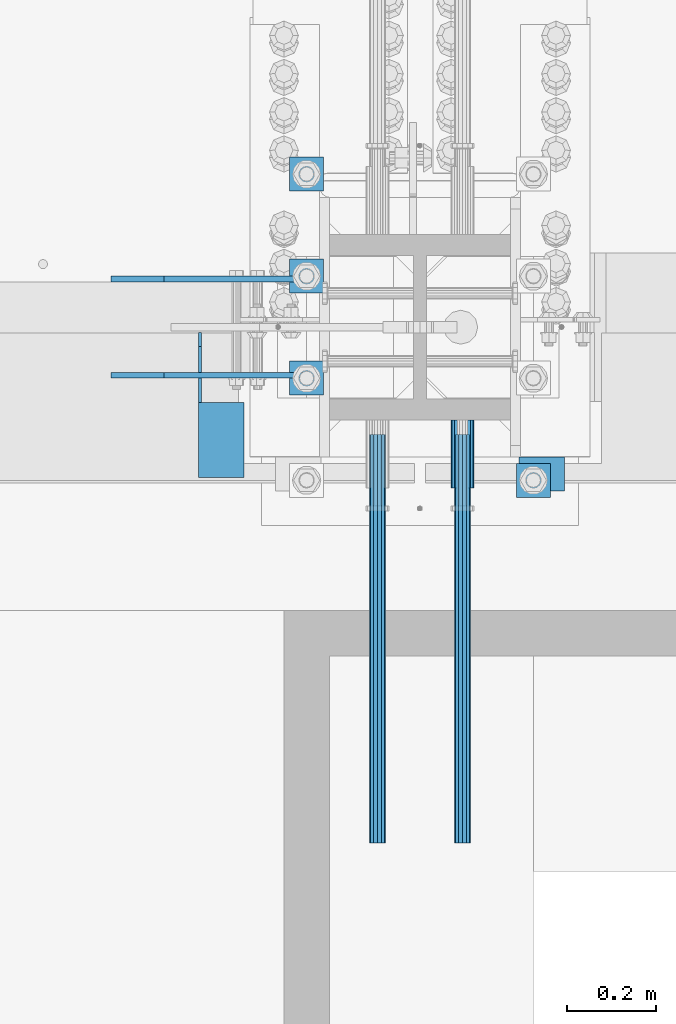
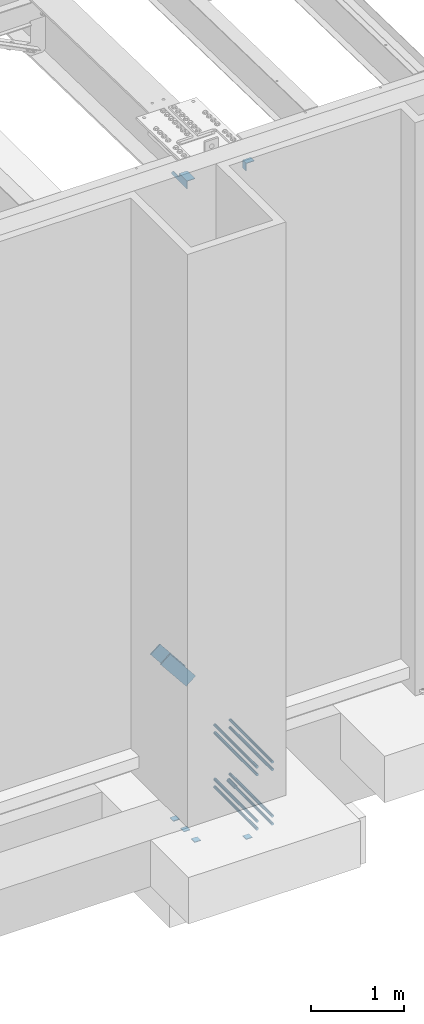
# One storey, part 1289 of 1763: 15 beams, 2 members, 13 elements without a shape of their own.
"""IFC2X3 building model written with IfcOpenShell, lengths in millimetres."""

from ifc_helpers import new_model, si_unit, frame, origin_with_axes, place, context, subcontext, project, spatial, faceted_brep, material, type_object, element, aggregate, save


model = new_model("IFC2X3")

# Units and contexts
model_context = context("Model", 3, precision=1e-05, world=origin_with_axes())
body_context = subcontext(model_context, "Body", "Model", "MODEL_VIEW")
ifc_project = project(units=[si_unit("LENGTHUNIT", "METRE", prefix="MILLI"), si_unit("AREAUNIT", "SQUARE_METRE"), si_unit("VOLUMEUNIT", "CUBIC_METRE"), si_unit("MASSUNIT", "GRAM", prefix="KILO"), si_unit("TIMEUNIT", "SECOND"), si_unit("PLANEANGLEUNIT", "RADIAN"), si_unit("SOLIDANGLEUNIT", "STERADIAN"), si_unit("THERMODYNAMICTEMPERATUREUNIT", "DEGREE_CELSIUS"), si_unit("LUMINOUSINTENSITYUNIT", "LUMEN")], contexts=[model_context])

# Site, building, storey
site_placement = place(None, origin_with_axes())
site = spatial("IfcSite", under=ifc_project, at=site_placement, CompositionType="ELEMENT")
building_placement = place(site_placement, origin_with_axes())
building = spatial("IfcBuilding", under=site, at=building_placement, Name="Undefined", CompositionType="ELEMENT")
storey_placement = place(building_placement, origin_with_axes())
storey = spatial("IfcBuildingStorey", under=building, at=storey_placement, Name="Undefined", CompositionType="ELEMENT", Elevation=0.0)

# Assembly, beam
assembly_1_placement = place(storey_placement, origin_with_axes())
assembly_1 = element("IfcElementAssembly", 1, at=assembly_1_placement, inside=storey, Name="COLUMN", AssemblyPlace="NOTDEFINED", PredefinedType="RIGID_FRAME")
ifc_material_1 = material(Name="STEEL/A36")
beam_type_1 = type_object("IfcBeamType", Name="L4X4X1/4", PredefinedType="NOTDEFINED")
beam_1_placement = place(assembly_1_placement, frame((-23754.7872728616, -14006.5123340175, 12153.9000001333), z_axis=(0.0, 0.0, -1.0), x_axis=(0.0, -1.0, 0.0)))
beam_1 = element("IfcBeam", 2, at=beam_1_placement, type_object=beam_type_1, material=ifc_material_1, Name="BRACE", ObjectType="L4X4X1/4", context=body_context, shape_type="Brep", body=[
    faceted_brep([(-3.63797880709171e-11, 50.8000000000011, -50.8000000000538), (-1.96450855582952e-10, 50.8000000000393, 50.7999999999374), (76.2000000000007, 50.7999999999993, 50.7999999999993), (76.2000000000007, 50.7999999999993, -50.7999999999993), (-1.81898940354586e-10, 44.4500000000371, 50.7999999999374), (76.2000000000007, 44.4500000000007, 50.7999999999993), (-2.18278728425503e-11, 44.4500000000007, -44.450000000048), (76.2000000000007, 44.4500000000007, -44.4500000000007), (1.96450855582952e-10, -50.8000000000338, -44.4499999999534), (76.2000000000007, -50.7999999999993, -44.4500000000007), (2.11002770811319e-10, -50.8000000000357, -50.799999999952), (76.2000000000007, -50.7999999999993, -50.7999999999993)], [[[0, 1, 2, 3]], [[1, 4, 5, 2]], [[4, 6, 7, 5]], [[6, 8, 9, 7]], [[8, 10, 11, 9]], [[10, 0, 3, 11]], [[5, 7, 9, 11, 3, 2]], [[10, 8, 6, 4, 1, 0]]]),
])
aggregate(assembly_1, [beam_1])

assembly_2_placement = place(storey_placement, origin_with_axes())
assembly_2 = element("IfcElementAssembly", 3, at=assembly_2_placement, inside=storey, Name="BEAM", AssemblyPlace="NOTDEFINED", PredefinedType="RIGID_FRAME")
beam_2_placement = place(assembly_2_placement, frame((-24473.2055562795, -13727.9060686172, 12153.8999999997), z_axis=(0.0, 0.0, -1.0), x_axis=(0.0, -1.0, 0.0)))
beam_2 = element("IfcBeam", 4, at=beam_2_placement, type_object=beam_type_1, material=ifc_material_1, Name="BRACE", ObjectType="L4X4X1/4", context=body_context, shape_type="Brep", body=[
    faceted_brep([(156.368567097667, 44.4500000000007, -6.34999980941575), (156.368567097667, 50.7999999999993, -6.34999980941575), (156.368568386746, 50.7999999999993, -50.7999999999993), (156.368568386746, -50.7999999999993, -50.7999999999993), (156.368568202592, -50.7999999999993, -44.4500000000007), (156.368568202592, 44.4500000000007, -44.4500000000007), (31.7499984742426, 44.4500000000007, -6.35000000027321), (31.7499984742426, 50.7999999999993, -6.35000038323415), (-1.81898940354586e-10, 44.4500000000371, 50.7999999999374), (-1.96450855582952e-10, 50.8000000000393, 50.7999999999374), (0.0, 50.7999999999993, 25.3999999997268), (0.0, 44.4500000000007, 25.3999999997268), (324.643737794, 44.4500000000007, 50.7999999999993), (324.643737794, 50.7999999999993, 50.7999999999993), (324.643737794, 44.4500000000007, -44.4500000000007), (324.643737794, -50.7999999999993, -44.4500000000007), (324.643737794, -50.7999999999993, -50.7999999999993), (324.643737794, 50.7999999999993, -50.7999999999993)], [[[0, 1, 2, 3, 4, 5]], [[1, 0, 6, 7]], [[8, 9, 10, 11]], [[9, 8, 12, 13]], [[12, 14, 15, 16, 17, 13]], [[15, 14, 5, 4]], [[16, 15, 4, 3]], [[17, 16, 3, 2]], [[9, 13, 17, 2, 1, 7, 10]], [[6, 11, 10, 7]], [[0, 5, 14, 12, 8, 11, 6]]]),
])
aggregate(assembly_2, [beam_2])

# Assembly, members
assembly_3_placement = place(storey_placement, origin_with_axes())
assembly_3 = element("IfcElementAssembly", 5, at=assembly_3_placement, inside=storey, Name="V. BRACE", AssemblyPlace="NOTDEFINED", PredefinedType="RIGID_FRAME")
member_type = type_object("IfcMemberType", PredefinedType="NOTDEFINED")
member_1_placement = place(assembly_3_placement, frame((-24661.1130788545, -13608.05, 5845.3684065153), z_axis=(0.780585099299328, 0.0, 0.625049520239683), x_axis=(0.625049520239684, 0.0, -0.780585099299327)))
member_1 = element("IfcMember", 6, at=member_1_placement, type_object=member_type, material=ifc_material_1, Name="PLATE", context=body_context, shape_type="Brep", body=[
    faceted_brep([(4.36557456851006e-11, 6.35000000000036, -76.2000000000044), (-4.72937244921923e-11, 6.35000000000036, 76.1999999999898), (507.999999999498, 6.35000000000036, 76.1999999995642), (507.999999999589, 6.35000000000036, -76.20000000043), (-4.72937244921923e-11, -6.35000000000036, 76.1999999999898), (507.999999999498, -6.35000000000036, 76.1999999995642), (4.36557456851006e-11, -6.35000000000036, -76.2000000000044), (507.999999999589, -6.35000000000036, -76.20000000043)], [[[0, 1, 2, 3]], [[1, 4, 5, 2]], [[4, 6, 7, 5]], [[6, 0, 3, 7]], [[5, 7, 3, 2]], [[6, 4, 1, 0]]]),
])
member_2_placement = place(assembly_3_placement, frame((-24661.1130788545, -13823.95, 5845.3684065153), z_axis=(0.780585099299328, 0.0, 0.625049520239683), x_axis=(0.625049520239684, 0.0, -0.780585099299327)))
member_2 = element("IfcMember", 7, at=member_2_placement, type_object=member_type, material=ifc_material_1, Name="PLATE", context=body_context, shape_type="Brep", body=[
    faceted_brep([(4.36557456851006e-11, 6.35000000000036, -76.2000000000044), (-4.72937244921923e-11, 6.35000000000036, 76.1999999999898), (507.999999999498, 6.35000000000036, 76.1999999995642), (507.999999999589, 6.35000000000036, -76.20000000043), (-4.72937244921923e-11, -6.35000000000036, 76.1999999999898), (507.999999999498, -6.35000000000036, 76.1999999995642), (4.36557456851006e-11, -6.35000000000036, -76.2000000000044), (507.999999999589, -6.35000000000036, -76.20000000043)], [[[0, 1, 2, 3]], [[1, 4, 5, 2]], [[4, 6, 7, 5]], [[6, 0, 3, 7]], [[5, 7, 3, 2]], [[6, 4, 1, 0]]]),
])
aggregate(assembly_3, [member_1, member_2])

# Assembly, beams
assembly_4_placement = place(storey_placement, origin_with_axes())
assembly_4 = element("IfcElementAssembly", 8, at=assembly_4_placement, inside=storey, Name="TEMPLATE", AssemblyPlace="NOTDEFINED", PredefinedType="RIGID_FRAME")
beam_type_2 = type_object("IfcBeamType", PredefinedType="NOTDEFINED")
beam_3_placement = place(assembly_4_placement, frame((-23773.8372736984, -14097.0000000001, 3348.0375), z_axis=(1.0, 0.0, 0.0), x_axis=(0.0, 1.0, 0.0)))
beam_3 = element("IfcBeam", 9, at=beam_3_placement, type_object=beam_type_2, material=ifc_material_1, Name="WASHER PLATE", context=body_context, shape_type="Brep", body=[
    faceted_brep([(0.0, 4.76249999999709, -38.1000000000004), (0.0, 4.76249999999709, 38.1000000000004), (76.2000000000007, 4.76249999999982, 38.0999999999985), (76.2000000000007, 4.76249999999982, -38.0999999999985), (0.0, -4.76249999999709, 38.1000000000004), (76.2000000000007, -4.76249999999982, 38.0999999999985), (0.0, -4.76249999999709, -38.1000000000004), (76.2000000000007, -4.76249999999982, -38.0999999999985)], [[[0, 1, 2, 3]], [[1, 4, 5, 2]], [[4, 6, 7, 5]], [[6, 0, 3, 7]], [[5, 7, 3, 2]], [[6, 4, 1, 0]]]),
])
beam_4_placement = place(assembly_4_placement, frame((-24281.8372736984, -13868.4000000001, 3348.0375), z_axis=(1.0, 0.0, 0.0), x_axis=(0.0, 1.0, 0.0)))
beam_4 = element("IfcBeam", 10, at=beam_4_placement, type_object=beam_type_2, material=ifc_material_1, Name="WASHER PLATE", context=body_context, shape_type="Brep", body=[
    faceted_brep([(0.0, 4.76249999999709, -38.1000000000004), (0.0, 4.76249999999709, 38.1000000000004), (76.2000000000007, 4.76249999999982, 38.0999999999985), (76.2000000000007, 4.76249999999982, -38.0999999999985), (0.0, -4.76249999999709, 38.1000000000004), (76.2000000000007, -4.76249999999982, 38.0999999999985), (0.0, -4.76249999999709, -38.1000000000004), (76.2000000000007, -4.76249999999982, -38.0999999999985)], [[[0, 1, 2, 3]], [[1, 4, 5, 2]], [[4, 6, 7, 5]], [[6, 0, 3, 7]], [[5, 7, 3, 2]], [[6, 4, 1, 0]]]),
])
beam_5_placement = place(assembly_4_placement, frame((-24281.8372736984, -13639.8000000001, 3348.0375), z_axis=(1.0, 0.0, 0.0), x_axis=(0.0, 1.0, 0.0)))
beam_5 = element("IfcBeam", 11, at=beam_5_placement, type_object=beam_type_2, material=ifc_material_1, Name="WASHER PLATE", context=body_context, shape_type="Brep", body=[
    faceted_brep([(0.0, 4.76249999999709, -38.1000000000004), (0.0, 4.76249999999709, 38.1000000000004), (76.2000000000007, 4.76249999999982, 38.0999999999985), (76.2000000000007, 4.76249999999982, -38.0999999999985), (0.0, -4.76249999999709, 38.1000000000004), (76.2000000000007, -4.76249999999982, 38.0999999999985), (0.0, -4.76249999999709, -38.1000000000004), (76.2000000000007, -4.76249999999982, -38.0999999999985)], [[[0, 1, 2, 3]], [[1, 4, 5, 2]], [[4, 6, 7, 5]], [[6, 0, 3, 7]], [[5, 7, 3, 2]], [[6, 4, 1, 0]]]),
])
beam_6_placement = place(assembly_4_placement, frame((-24281.8372736984, -13411.2000000001, 3348.0375), z_axis=(1.0, 0.0, 0.0), x_axis=(0.0, 1.0, 0.0)))
beam_6 = element("IfcBeam", 12, at=beam_6_placement, type_object=beam_type_2, material=ifc_material_1, Name="WASHER PLATE", context=body_context, shape_type="Brep", body=[
    faceted_brep([(0.0, 4.76249999999709, -38.1000000000004), (0.0, 4.76249999999709, 38.1000000000004), (76.2000000000007, 4.76249999999982, 38.0999999999985), (76.2000000000007, 4.76249999999982, -38.0999999999985), (0.0, -4.76249999999709, 38.1000000000004), (76.2000000000007, -4.76249999999982, 38.0999999999985), (0.0, -4.76249999999709, -38.1000000000004), (76.2000000000007, -4.76249999999982, -38.0999999999985)], [[[0, 1, 2, 3]], [[1, 4, 5, 2]], [[4, 6, 7, 5]], [[6, 0, 3, 7]], [[5, 7, 3, 2]], [[6, 4, 1, 0]]]),
])
aggregate(assembly_4, [beam_3, beam_4, beam_5, beam_6])

# Assembly, beam
assembly_5_placement = place(storey_placement, origin_with_axes())
assembly_5 = element("IfcElementAssembly", 13, at=assembly_5_placement, inside=storey, Name="HALF COUPLER", AssemblyPlace="NOTDEFINED", PredefinedType="RIGID_FRAME")
ifc_material_2 = material(Name="STEEL/A706-GR.80")
beam_type_3 = type_object("IfcBeamType", PredefinedType="NOTDEFINED")
beam_7_placement = place(assembly_5_placement, frame((-23932.5872736985, -13923.9622483743, 4064.0), z_axis=(0.0, 0.0, 1.0), x_axis=(0.0, -1.0, 0.0)))
beam_7 = element("IfcBeam", 14, at=beam_7_placement, type_object=beam_type_3, material=ifc_material_2, Name="HALF COUPLER", context=body_context, shape_type="Brep", body=[
    faceted_brep([(32.7659999999996, -8.95349999999962, -15.507916905568), (32.7659999999996, 0.0, -17.9070000000002), (32.7659999999996, 8.95349999999962, -15.507916905568), (32.7659999999996, 15.507916905568, -8.95350000000008), (32.7659999999996, 17.9069999999992, 0.0), (32.7659999999996, 15.507916905568, 8.95350000000008), (32.7659999999996, 8.95349999999962, 15.507916905568), (32.7659999999996, 0.0, 17.9070000000002), (32.7659999999996, -8.95349999999962, 15.507916905568), (32.7659999999996, -15.507916905568, 8.95350000000008), (32.7659999999996, -17.9069999999992, 0.0), (32.7659999999996, -15.507916905568, -8.95350000000008), (152.400103102711, -15.507916905568, 8.95350000000008), (152.400103102711, -8.95349999999962, 15.507916905568), (152.400103102711, -17.9069999999992, 0.0), (152.400103102711, -15.507916905568, -8.95350000000008), (152.400103102711, -8.95349999999962, -15.507916905568), (152.400103102711, 0.0, -17.9070000000002), (152.400103102711, 8.95349999999962, -15.507916905568), (152.400103102711, 15.507916905568, -8.95350000000008), (152.400103102711, 17.9069999999992, 0.0), (152.400103102711, 15.507916905568, 8.95350000000008), (152.400103102711, 8.95349999999962, 15.507916905568), (152.400103102711, 0.0, 17.9070000000002), (0.0, -23.466540125788, 9.72015918207308), (0.0, -17.9605122421381, 17.9605122421385), (0.0, -9.72015918207398, 23.4665401257867), (0.0, 0.0, 25.4000000000001), (0.0, 9.72015918207398, 23.4665401257867), (0.0, 17.9605122421381, 17.9605122421385), (0.0, 23.466540125788, 9.72015918207308), (0.0, 25.4000000000015, 0.0), (0.0, 23.466540125788, -9.72015918207308), (0.0, 17.9605122421381, -17.9605122421385), (0.0, 9.72015918207398, -23.4665401257867), (0.0, 0.0, -25.4000000000001), (0.0, -9.72015918207398, -23.4665401257867), (0.0, -17.9605122421381, -17.9605122421385), (0.0, -23.466540125788, -9.72015918207308), (0.0, -25.4000000000015, 0.0), (152.400103102711, -25.4000000000015, 0.0), (152.400103102711, -23.466540125788, 9.72015918207308), (152.400103102711, -17.9605122421381, 17.9605122421385), (152.400103102711, -9.72015918207398, 23.4665401257867), (152.400103102711, 0.0, 25.4000000000001), (152.400103102711, 9.72015918207398, 23.4665401257867), (152.400103102711, 17.9605122421381, 17.9605122421385), (152.400103102711, 23.466540125788, 9.72015918207308), (152.400103102711, 25.4000000000015, 0.0), (152.400103102711, 23.466540125788, -9.72015918207308), (152.400103102711, 17.9605122421381, -17.9605122421385), (152.400103102711, 9.72015918207398, -23.4665401257867), (152.400103102711, 0.0, -25.4000000000001), (152.400103102711, -9.72015918207398, -23.4665401257867), (152.400103102711, -17.9605122421381, -17.9605122421385), (152.400103102711, -23.466540125788, -9.72015918207308)], [[[0, 1, 2, 3, 4, 5, 6, 7, 8, 9, 10, 11]], [[12, 9, 8, 13]], [[14, 10, 9, 12]], [[15, 11, 10, 14]], [[16, 0, 11, 15]], [[17, 1, 0, 16]], [[18, 2, 1, 17]], [[19, 3, 2, 18]], [[20, 4, 3, 19]], [[21, 5, 4, 20]], [[22, 6, 5, 21]], [[23, 7, 6, 22]], [[13, 8, 7, 23]], [[24, 25, 26, 27, 28, 29, 30, 31, 32, 33, 34, 35, 36, 37, 38, 39]], [[24, 39, 40, 41]], [[25, 24, 41, 42]], [[26, 25, 42, 43]], [[27, 26, 43, 44]], [[28, 27, 44, 45]], [[29, 28, 45, 46]], [[30, 29, 46, 47]], [[31, 30, 47, 48]], [[32, 31, 48, 49]], [[33, 32, 49, 50]], [[34, 33, 50, 51]], [[35, 34, 51, 52]], [[36, 35, 52, 53]], [[37, 36, 53, 54]], [[38, 37, 54, 55]], [[39, 38, 55, 40]], [[54, 53, 52, 51, 50, 49, 48, 47, 46, 45, 44, 43, 42, 41, 40, 55], [21, 20, 19, 18, 17, 16, 15, 14, 12, 13, 23, 22]]]),
])
aggregate(assembly_5, [beam_7])

assembly_6_placement = place(storey_placement, origin_with_axes())
assembly_6 = element("IfcElementAssembly", 15, at=assembly_6_placement, inside=storey, Name="REBAR", AssemblyPlace="NOTDEFINED", PredefinedType="RIGID_FRAME")
beam_type_4 = type_object("IfcBeamType", Name="#11 REBAR", PredefinedType="NOTDEFINED")
beam_8_placement = place(assembly_6_placement, frame((-23932.5872736985, -13956.7282483743, 4165.60000000009), z_axis=(0.0, 0.0, 1.0), x_axis=(0.0, -1.0, 0.0)))
beam_8 = element("IfcBeam", 16, at=beam_8_placement, type_object=beam_type_4, material=ifc_material_2, Name="REBAR", ObjectType="#11 REBAR", context=body_context, shape_type="Brep", body=[
    faceted_brep([(0.0, -17.9069999999992, 0.0), (0.0, -15.507916905568, -8.95349999999962), (914.400000001086, -15.507916905568, -8.95349999999962), (914.400000001086, -17.9069999999992, 0.0), (0.0, -8.95349999999962, -15.507916905568), (914.400000001086, -8.95349999999962, -15.507916905568), (0.0, 0.0, -17.9070000000002), (914.400000001086, 0.0, -17.9070000000002), (0.0, 8.95349999999962, -15.507916905568), (914.400000001086, 8.95349999999962, -15.507916905568), (0.0, 15.507916905568, -8.95349999999962), (914.400000001086, 15.507916905568, -8.95349999999962), (0.0, 17.9069999999992, 0.0), (914.400000001086, 17.9069999999992, 0.0), (0.0, 15.507916905568, 8.95349999999962), (914.400000001086, 15.507916905568, 8.95349999999962), (0.0, 8.95349999999962, 15.507916905568), (914.400000001086, 8.95349999999962, 15.507916905568), (0.0, 0.0, 17.9070000000002), (914.400000001086, 0.0, 17.9070000000002), (0.0, -8.95349999999962, 15.507916905568), (914.400000001086, -8.95349999999962, 15.507916905568), (0.0, -15.507916905568, 8.95349999999962), (914.400000001086, -15.507916905568, 8.95349999999962)], [[[0, 1, 2, 3]], [[1, 4, 5, 2]], [[4, 6, 7, 5]], [[6, 8, 9, 7]], [[8, 10, 11, 9]], [[10, 12, 13, 11]], [[12, 14, 15, 13]], [[14, 16, 17, 15]], [[16, 18, 19, 17]], [[18, 20, 21, 19]], [[20, 22, 23, 21]], [[22, 0, 3, 23]], [[5, 7, 9, 11, 13, 15, 17, 19, 21, 23, 3, 2]], [[22, 20, 18, 16, 14, 12, 10, 8, 6, 4, 1, 0]]]),
])
aggregate(assembly_6, [beam_8])

assembly_7_placement = place(storey_placement, origin_with_axes())
assembly_7 = element("IfcElementAssembly", 17, at=assembly_7_placement, inside=storey, Name="REBAR", AssemblyPlace="NOTDEFINED", PredefinedType="RIGID_FRAME")
beam_9_placement = place(assembly_7_placement, frame((-24123.0872736984, -13956.7283171098, 4165.60000000009), z_axis=(0.0, 0.0, 1.0), x_axis=(0.0, -1.0, 0.0)))
beam_9 = element("IfcBeam", 18, at=beam_9_placement, type_object=beam_type_4, material=ifc_material_2, Name="REBAR", ObjectType="#11 REBAR", context=body_context, shape_type="Brep", body=[
    faceted_brep([(0.0, -17.9069999999992, 0.0), (0.0, -15.507916905568, -8.95349999999962), (914.400000001086, -15.507916905568, -8.95349999999962), (914.400000001086, -17.9069999999992, 0.0), (0.0, -8.95349999999962, -15.507916905568), (914.400000001086, -8.95349999999962, -15.507916905568), (0.0, 0.0, -17.9070000000002), (914.400000001086, 0.0, -17.9070000000002), (0.0, 8.95349999999962, -15.507916905568), (914.400000001086, 8.95349999999962, -15.507916905568), (0.0, 15.507916905568, -8.95349999999962), (914.400000001086, 15.507916905568, -8.95349999999962), (0.0, 17.9069999999992, 0.0), (914.400000001086, 17.9069999999992, 0.0), (0.0, 15.507916905568, 8.95349999999962), (914.400000001086, 15.507916905568, 8.95349999999962), (0.0, 8.95349999999962, 15.507916905568), (914.400000001086, 8.95349999999962, 15.507916905568), (0.0, 0.0, 17.9070000000002), (914.400000001086, 0.0, 17.9070000000002), (0.0, -8.95349999999962, 15.507916905568), (914.400000001086, -8.95349999999962, 15.507916905568), (0.0, -15.507916905568, 8.95349999999962), (914.400000001086, -15.507916905568, 8.95349999999962)], [[[0, 1, 2, 3]], [[1, 4, 5, 2]], [[4, 6, 7, 5]], [[6, 8, 9, 7]], [[8, 10, 11, 9]], [[10, 12, 13, 11]], [[12, 14, 15, 13]], [[14, 16, 17, 15]], [[16, 18, 19, 17]], [[18, 20, 21, 19]], [[20, 22, 23, 21]], [[22, 0, 3, 23]], [[5, 7, 9, 11, 13, 15, 17, 19, 21, 23, 3, 2]], [[22, 20, 18, 16, 14, 12, 10, 8, 6, 4, 1, 0]]]),
])
aggregate(assembly_7, [beam_9])

assembly_8_placement = place(storey_placement, origin_with_axes())
assembly_8 = element("IfcElementAssembly", 19, at=assembly_8_placement, inside=storey, Name="REBAR", AssemblyPlace="NOTDEFINED", PredefinedType="RIGID_FRAME")
beam_10_placement = place(assembly_8_placement, frame((-23932.5872736985, -13956.7282483743, 4064.00000000009), z_axis=(0.0, 0.0, 1.0), x_axis=(0.0, -1.0, 0.0)))
beam_10 = element("IfcBeam", 20, at=beam_10_placement, type_object=beam_type_4, material=ifc_material_2, Name="REBAR", ObjectType="#11 REBAR", context=body_context, shape_type="Brep", body=[
    faceted_brep([(0.0, -17.9069999999992, 0.0), (0.0, -15.507916905568, -8.95349999999962), (914.400000001086, -15.507916905568, -8.95349999999962), (914.400000001086, -17.9069999999992, 0.0), (0.0, -8.95349999999962, -15.507916905568), (914.400000001086, -8.95349999999962, -15.507916905568), (0.0, 0.0, -17.9070000000002), (914.400000001086, 0.0, -17.9070000000002), (0.0, 8.95349999999962, -15.507916905568), (914.400000001086, 8.95349999999962, -15.507916905568), (0.0, 15.507916905568, -8.95349999999962), (914.400000001086, 15.507916905568, -8.95349999999962), (0.0, 17.9069999999992, 0.0), (914.400000001086, 17.9069999999992, 0.0), (0.0, 15.507916905568, 8.95349999999962), (914.400000001086, 15.507916905568, 8.95349999999962), (0.0, 8.95349999999962, 15.507916905568), (914.400000001086, 8.95349999999962, 15.507916905568), (0.0, 0.0, 17.9070000000002), (914.400000001086, 0.0, 17.9070000000002), (0.0, -8.95349999999962, 15.507916905568), (914.400000001086, -8.95349999999962, 15.507916905568), (0.0, -15.507916905568, 8.95349999999962), (914.400000001086, -15.507916905568, 8.95349999999962)], [[[0, 1, 2, 3]], [[1, 4, 5, 2]], [[4, 6, 7, 5]], [[6, 8, 9, 7]], [[8, 10, 11, 9]], [[10, 12, 13, 11]], [[12, 14, 15, 13]], [[14, 16, 17, 15]], [[16, 18, 19, 17]], [[18, 20, 21, 19]], [[20, 22, 23, 21]], [[22, 0, 3, 23]], [[5, 7, 9, 11, 13, 15, 17, 19, 21, 23, 3, 2]], [[22, 20, 18, 16, 14, 12, 10, 8, 6, 4, 1, 0]]]),
])
aggregate(assembly_8, [beam_10])

assembly_9_placement = place(storey_placement, origin_with_axes())
assembly_9 = element("IfcElementAssembly", 21, at=assembly_9_placement, inside=storey, Name="REBAR", AssemblyPlace="NOTDEFINED", PredefinedType="RIGID_FRAME")
beam_11_placement = place(assembly_9_placement, frame((-24123.0872736984, -13956.7283171098, 4064.00000000009), z_axis=(0.0, 0.0, 1.0), x_axis=(0.0, -1.0, 0.0)))
beam_11 = element("IfcBeam", 22, at=beam_11_placement, type_object=beam_type_4, material=ifc_material_2, Name="REBAR", ObjectType="#11 REBAR", context=body_context, shape_type="Brep", body=[
    faceted_brep([(0.0, -17.9069999999992, 0.0), (0.0, -15.507916905568, -8.95349999999962), (914.400000001086, -15.507916905568, -8.95349999999962), (914.400000001086, -17.9069999999992, 0.0), (0.0, -8.95349999999962, -15.507916905568), (914.400000001086, -8.95349999999962, -15.507916905568), (0.0, 0.0, -17.9070000000002), (914.400000001086, 0.0, -17.9070000000002), (0.0, 8.95349999999962, -15.507916905568), (914.400000001086, 8.95349999999962, -15.507916905568), (0.0, 15.507916905568, -8.95349999999962), (914.400000001086, 15.507916905568, -8.95349999999962), (0.0, 17.9069999999992, 0.0), (914.400000001086, 17.9069999999992, 0.0), (0.0, 15.507916905568, 8.95349999999962), (914.400000001086, 15.507916905568, 8.95349999999962), (0.0, 8.95349999999962, 15.507916905568), (914.400000001086, 8.95349999999962, 15.507916905568), (0.0, 0.0, 17.9070000000002), (914.400000001086, 0.0, 17.9070000000002), (0.0, -8.95349999999962, 15.507916905568), (914.400000001086, -8.95349999999962, 15.507916905568), (0.0, -15.507916905568, 8.95349999999962), (914.400000001086, -15.507916905568, 8.95349999999962)], [[[0, 1, 2, 3]], [[1, 4, 5, 2]], [[4, 6, 7, 5]], [[6, 8, 9, 7]], [[8, 10, 11, 9]], [[10, 12, 13, 11]], [[12, 14, 15, 13]], [[14, 16, 17, 15]], [[16, 18, 19, 17]], [[18, 20, 21, 19]], [[20, 22, 23, 21]], [[22, 0, 3, 23]], [[5, 7, 9, 11, 13, 15, 17, 19, 21, 23, 3, 2]], [[22, 20, 18, 16, 14, 12, 10, 8, 6, 4, 1, 0]]]),
])
aggregate(assembly_9, [beam_11])

assembly_10_placement = place(storey_placement, origin_with_axes())
assembly_10 = element("IfcElementAssembly", 23, at=assembly_10_placement, inside=storey, Name="REBAR", AssemblyPlace="NOTDEFINED", PredefinedType="RIGID_FRAME")
beam_12_placement = place(assembly_10_placement, frame((-23932.5872736985, -13956.7285233158, 4876.80000000009), z_axis=(0.0, 0.0, 1.0), x_axis=(0.0, -1.0, 0.0)))
beam_12 = element("IfcBeam", 24, at=beam_12_placement, type_object=beam_type_4, material=ifc_material_2, Name="REBAR", ObjectType="#11 REBAR", context=body_context, shape_type="Brep", body=[
    faceted_brep([(0.0, -17.9069999999992, 0.0), (0.0, -15.507916905568, -8.95349999999962), (914.400000001086, -15.507916905568, -8.95349999999962), (914.400000001086, -17.9069999999992, 0.0), (0.0, -8.95349999999962, -15.507916905568), (914.400000001086, -8.95349999999962, -15.507916905568), (0.0, 0.0, -17.9070000000002), (914.400000001086, 0.0, -17.9070000000002), (0.0, 8.95349999999962, -15.507916905568), (914.400000001086, 8.95349999999962, -15.507916905568), (0.0, 15.507916905568, -8.95349999999962), (914.400000001086, 15.507916905568, -8.95349999999962), (0.0, 17.9069999999992, 0.0), (914.400000001086, 17.9069999999992, 0.0), (0.0, 15.507916905568, 8.95349999999962), (914.400000001086, 15.507916905568, 8.95349999999962), (0.0, 8.95349999999962, 15.507916905568), (914.400000001086, 8.95349999999962, 15.507916905568), (0.0, 0.0, 17.9070000000002), (914.400000001086, 0.0, 17.9070000000002), (0.0, -8.95349999999962, 15.507916905568), (914.400000001086, -8.95349999999962, 15.507916905568), (0.0, -15.507916905568, 8.95349999999962), (914.400000001086, -15.507916905568, 8.95349999999962)], [[[0, 1, 2, 3]], [[1, 4, 5, 2]], [[4, 6, 7, 5]], [[6, 8, 9, 7]], [[8, 10, 11, 9]], [[10, 12, 13, 11]], [[12, 14, 15, 13]], [[14, 16, 17, 15]], [[16, 18, 19, 17]], [[18, 20, 21, 19]], [[20, 22, 23, 21]], [[22, 0, 3, 23]], [[5, 7, 9, 11, 13, 15, 17, 19, 21, 23, 3, 2]], [[22, 20, 18, 16, 14, 12, 10, 8, 6, 4, 1, 0]]]),
])
aggregate(assembly_10, [beam_12])

assembly_11_placement = place(storey_placement, origin_with_axes())
assembly_11 = element("IfcElementAssembly", 25, at=assembly_11_placement, inside=storey, Name="REBAR", AssemblyPlace="NOTDEFINED", PredefinedType="RIGID_FRAME")
beam_13_placement = place(assembly_11_placement, frame((-24123.0872736984, -13956.7285920513, 4876.80000000009), z_axis=(0.0, 0.0, 1.0), x_axis=(0.0, -1.0, 0.0)))
beam_13 = element("IfcBeam", 26, at=beam_13_placement, type_object=beam_type_4, material=ifc_material_2, Name="REBAR", ObjectType="#11 REBAR", context=body_context, shape_type="Brep", body=[
    faceted_brep([(0.0, -17.9069999999992, 0.0), (0.0, -15.507916905568, -8.95349999999962), (914.400000001086, -15.507916905568, -8.95349999999962), (914.400000001086, -17.9069999999992, 0.0), (0.0, -8.95349999999962, -15.507916905568), (914.400000001086, -8.95349999999962, -15.507916905568), (0.0, 0.0, -17.9070000000002), (914.400000001086, 0.0, -17.9070000000002), (0.0, 8.95349999999962, -15.507916905568), (914.400000001086, 8.95349999999962, -15.507916905568), (0.0, 15.507916905568, -8.95349999999962), (914.400000001086, 15.507916905568, -8.95349999999962), (0.0, 17.9069999999992, 0.0), (914.400000001086, 17.9069999999992, 0.0), (0.0, 15.507916905568, 8.95349999999962), (914.400000001086, 15.507916905568, 8.95349999999962), (0.0, 8.95349999999962, 15.507916905568), (914.400000001086, 8.95349999999962, 15.507916905568), (0.0, 0.0, 17.9070000000002), (914.400000001086, 0.0, 17.9070000000002), (0.0, -8.95349999999962, 15.507916905568), (914.400000001086, -8.95349999999962, 15.507916905568), (0.0, -15.507916905568, 8.95349999999962), (914.400000001086, -15.507916905568, 8.95349999999962)], [[[0, 1, 2, 3]], [[1, 4, 5, 2]], [[4, 6, 7, 5]], [[6, 8, 9, 7]], [[8, 10, 11, 9]], [[10, 12, 13, 11]], [[12, 14, 15, 13]], [[14, 16, 17, 15]], [[16, 18, 19, 17]], [[18, 20, 21, 19]], [[20, 22, 23, 21]], [[22, 0, 3, 23]], [[5, 7, 9, 11, 13, 15, 17, 19, 21, 23, 3, 2]], [[22, 20, 18, 16, 14, 12, 10, 8, 6, 4, 1, 0]]]),
])
aggregate(assembly_11, [beam_13])

assembly_12_placement = place(storey_placement, origin_with_axes())
assembly_12 = element("IfcElementAssembly", 27, at=assembly_12_placement, inside=storey, Name="REBAR", AssemblyPlace="NOTDEFINED", PredefinedType="RIGID_FRAME")
beam_14_placement = place(assembly_12_placement, frame((-23932.5872736985, -13956.7285233158, 4775.20000000009), z_axis=(0.0, 0.0, 1.0), x_axis=(0.0, -1.0, 0.0)))
beam_14 = element("IfcBeam", 28, at=beam_14_placement, type_object=beam_type_4, material=ifc_material_2, Name="REBAR", ObjectType="#11 REBAR", context=body_context, shape_type="Brep", body=[
    faceted_brep([(0.0, -17.9069999999992, 0.0), (0.0, -15.507916905568, -8.95349999999962), (914.400000001086, -15.507916905568, -8.95349999999962), (914.400000001086, -17.9069999999992, 0.0), (0.0, -8.95349999999962, -15.507916905568), (914.400000001086, -8.95349999999962, -15.507916905568), (0.0, 0.0, -17.9070000000002), (914.400000001086, 0.0, -17.9070000000002), (0.0, 8.95349999999962, -15.507916905568), (914.400000001086, 8.95349999999962, -15.507916905568), (0.0, 15.507916905568, -8.95349999999962), (914.400000001086, 15.507916905568, -8.95349999999962), (0.0, 17.9069999999992, 0.0), (914.400000001086, 17.9069999999992, 0.0), (0.0, 15.507916905568, 8.95349999999962), (914.400000001086, 15.507916905568, 8.95349999999962), (0.0, 8.95349999999962, 15.507916905568), (914.400000001086, 8.95349999999962, 15.507916905568), (0.0, 0.0, 17.9070000000002), (914.400000001086, 0.0, 17.9070000000002), (0.0, -8.95349999999962, 15.507916905568), (914.400000001086, -8.95349999999962, 15.507916905568), (0.0, -15.507916905568, 8.95349999999962), (914.400000001086, -15.507916905568, 8.95349999999962)], [[[0, 1, 2, 3]], [[1, 4, 5, 2]], [[4, 6, 7, 5]], [[6, 8, 9, 7]], [[8, 10, 11, 9]], [[10, 12, 13, 11]], [[12, 14, 15, 13]], [[14, 16, 17, 15]], [[16, 18, 19, 17]], [[18, 20, 21, 19]], [[20, 22, 23, 21]], [[22, 0, 3, 23]], [[5, 7, 9, 11, 13, 15, 17, 19, 21, 23, 3, 2]], [[22, 20, 18, 16, 14, 12, 10, 8, 6, 4, 1, 0]]]),
])
aggregate(assembly_12, [beam_14])

assembly_13_placement = place(storey_placement, origin_with_axes())
assembly_13 = element("IfcElementAssembly", 29, at=assembly_13_placement, inside=storey, Name="REBAR", AssemblyPlace="NOTDEFINED", PredefinedType="RIGID_FRAME")
beam_15_placement = place(assembly_13_placement, frame((-24123.0872736984, -13956.7285920513, 4775.20000000009), z_axis=(0.0, 0.0, 1.0), x_axis=(0.0, -1.0, 0.0)))
beam_15 = element("IfcBeam", 30, at=beam_15_placement, type_object=beam_type_4, material=ifc_material_2, Name="REBAR", ObjectType="#11 REBAR", context=body_context, shape_type="Brep", body=[
    faceted_brep([(0.0, -17.9069999999992, 0.0), (0.0, -15.507916905568, -8.95349999999962), (914.400000001086, -15.507916905568, -8.95349999999962), (914.400000001086, -17.9069999999992, 0.0), (0.0, -8.95349999999962, -15.507916905568), (914.400000001086, -8.95349999999962, -15.507916905568), (0.0, 0.0, -17.9070000000002), (914.400000001086, 0.0, -17.9070000000002), (0.0, 8.95349999999962, -15.507916905568), (914.400000001086, 8.95349999999962, -15.507916905568), (0.0, 15.507916905568, -8.95349999999962), (914.400000001086, 15.507916905568, -8.95349999999962), (0.0, 17.9069999999992, 0.0), (914.400000001086, 17.9069999999992, 0.0), (0.0, 15.507916905568, 8.95349999999962), (914.400000001086, 15.507916905568, 8.95349999999962), (0.0, 8.95349999999962, 15.507916905568), (914.400000001086, 8.95349999999962, 15.507916905568), (0.0, 0.0, 17.9070000000002), (914.400000001086, 0.0, 17.9070000000002), (0.0, -8.95349999999962, 15.507916905568), (914.400000001086, -8.95349999999962, 15.507916905568), (0.0, -15.507916905568, 8.95349999999962), (914.400000001086, -15.507916905568, 8.95349999999962)], [[[0, 1, 2, 3]], [[1, 4, 5, 2]], [[4, 6, 7, 5]], [[6, 8, 9, 7]], [[8, 10, 11, 9]], [[10, 12, 13, 11]], [[12, 14, 15, 13]], [[14, 16, 17, 15]], [[16, 18, 19, 17]], [[18, 20, 21, 19]], [[20, 22, 23, 21]], [[22, 0, 3, 23]], [[5, 7, 9, 11, 13, 15, 17, 19, 21, 23, 3, 2]], [[22, 20, 18, 16, 14, 12, 10, 8, 6, 4, 1, 0]]]),
])
aggregate(assembly_13, [beam_15])

save(model, "model.ifc")
